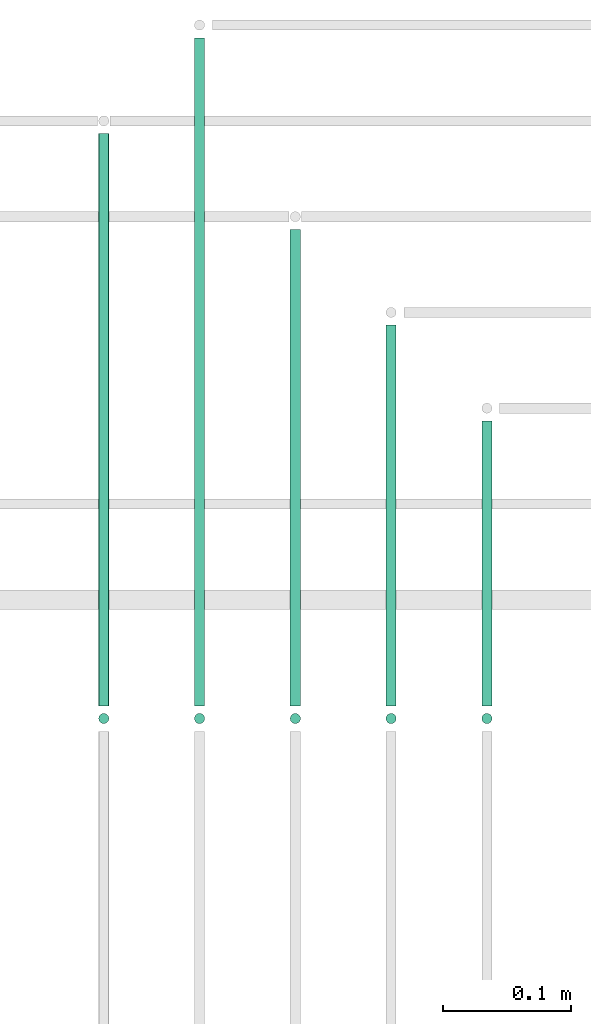
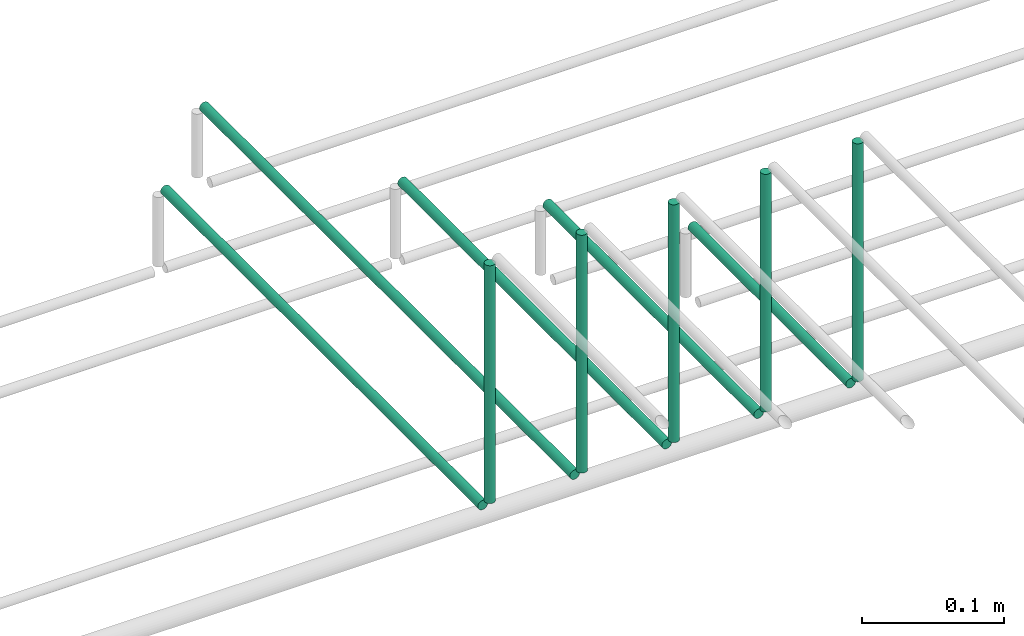
# One storey, part 44 of 89: 10 flow segments.
"""IFC2X3 building model written with IfcOpenShell, lengths in millimetres."""

from ifc_helpers import new_model, entity, si_unit, converted_unit, derived_unit, direction, frame, origin, origin_2d_with_axis, place, context, subcontext, project, spatial, circle, extrude, type_object, element, save


model = new_model("IFC2X3")

# Units and contexts
model_context = context("Model", 3, precision=0.01, world=origin(), true_north=direction((6.12303176911189e-17, 1.0)))
body_context = subcontext(model_context, "Body", "Model", "MODEL_VIEW")
ifc_project = project(units=[si_unit("LENGTHUNIT", "METRE", prefix="MILLI"), si_unit("AREAUNIT", "SQUARE_METRE"), si_unit("VOLUMEUNIT", "CUBIC_METRE"), converted_unit("PLANEANGLEUNIT", "DEGREE", entity("IfcRatioMeasure", 0.0174532925199433), si_unit("PLANEANGLEUNIT", "RADIAN"), dimensions=[0, 0, 0, 0, 0, 0, 0]), si_unit("MASSUNIT", "GRAM", prefix="KILO"), derived_unit("MASSDENSITYUNIT", [(si_unit("MASSUNIT", "GRAM", prefix="KILO"), 1), (si_unit("LENGTHUNIT", "METRE"), -3)]), derived_unit("MOMENTOFINERTIAUNIT", [(si_unit("LENGTHUNIT", "METRE"), 4)]), si_unit("TIMEUNIT", "SECOND"), si_unit("FREQUENCYUNIT", "HERTZ"), si_unit("THERMODYNAMICTEMPERATUREUNIT", "DEGREE_CELSIUS"), derived_unit("THERMALTRANSMITTANCEUNIT", [(si_unit("MASSUNIT", "GRAM", prefix="KILO"), 1), (si_unit("THERMODYNAMICTEMPERATUREUNIT", "KELVIN"), -1), (si_unit("TIMEUNIT", "SECOND"), -3)]), derived_unit("VOLUMETRICFLOWRATEUNIT", [(si_unit("LENGTHUNIT", "METRE"), 3), (si_unit("TIMEUNIT", "SECOND"), -1)]), derived_unit("MASSFLOWRATEUNIT", [(si_unit("MASSUNIT", "GRAM", prefix="KILO"), 1), (si_unit("TIMEUNIT", "SECOND"), -1)]), derived_unit("ROTATIONALFREQUENCYUNIT", [(si_unit("TIMEUNIT", "SECOND"), -1)]), si_unit("ELECTRICCURRENTUNIT", "AMPERE"), si_unit("ELECTRICVOLTAGEUNIT", "VOLT"), si_unit("POWERUNIT", "WATT"), si_unit("FORCEUNIT", "NEWTON", prefix="KILO"), si_unit("ILLUMINANCEUNIT", "LUX"), si_unit("LUMINOUSFLUXUNIT", "LUMEN"), si_unit("LUMINOUSINTENSITYUNIT", "CANDELA"), derived_unit("USERDEFINED", [(si_unit("MASSUNIT", "GRAM", prefix="KILO"), -1), (si_unit("LENGTHUNIT", "METRE"), -2), (si_unit("TIMEUNIT", "SECOND"), 3), (si_unit("LUMINOUSFLUXUNIT", "LUMEN"), 1)]), derived_unit("LINEARVELOCITYUNIT", [(si_unit("LENGTHUNIT", "METRE"), 1), (si_unit("TIMEUNIT", "SECOND"), -1)]), si_unit("PRESSUREUNIT", "PASCAL"), derived_unit("USERDEFINED", [(si_unit("LENGTHUNIT", "METRE"), -2), (si_unit("MASSUNIT", "GRAM", prefix="KILO"), 1), (si_unit("TIMEUNIT", "SECOND"), -2)]), derived_unit("LINEARFORCEUNIT", [(si_unit("MASSUNIT", "GRAM", prefix="KILO"), 1), (si_unit("LENGTHUNIT", "METRE"), 1), (si_unit("TIMEUNIT", "SECOND"), -2), (si_unit("LENGTHUNIT", "METRE"), -1)]), derived_unit("PLANARFORCEUNIT", [(si_unit("MASSUNIT", "GRAM", prefix="KILO"), 1), (si_unit("LENGTHUNIT", "METRE"), 1), (si_unit("TIMEUNIT", "SECOND"), -2), (si_unit("LENGTHUNIT", "METRE"), -2)])], contexts=[model_context])

# Site, building, storey
site_placement = place(None, frame((0.0, -0.00077364408347762, 0.0)))
site = spatial("IfcSite", under=ifc_project, at=site_placement, CompositionType="ELEMENT")
building_placement = place(site_placement, origin())
building = spatial("IfcBuilding", under=site, at=building_placement, CompositionType="ELEMENT")
storey_placement = place(building_placement, frame((0.0, 0.0, 24000.0)))
storey = spatial("IfcBuildingStorey", under=building, at=storey_placement, CompositionType="ELEMENT", Elevation=24000.0)

# Flow segments
pipe_segment_type = type_object("IfcPipeSegmentType", PredefinedType="NOTDEFINED")
flow_segment_1_placement = place(storey_placement, frame((45839.1209292422, 18567.0, 2844.4047277641)))
element("IfcFlowSegment", 1, at=flow_segment_1_placement, inside=storey, type_object=pipe_segment_type, context=body_context, shape_type="SweptSolid", body=[
    extrude(circle(Radius=4.0, at=origin_2d_with_axis()), frame((5.59527223591499, 0.0, 5.59527223591499), z_axis=(0.0, 1.0, 0.0), x_axis=(-1.0, 0.0, 0.0)), (0.0, 0.0, 1.0), 448.000007308937),
])
flow_segment_2_placement = place(storey_placement, frame((45839.1209292422, 18551.4047204553, 2860.0)))
element("IfcFlowSegment", 2, at=flow_segment_2_placement, inside=storey, type_object=pipe_segment_type, context=body_context, shape_type="SweptSolid", body=[
    extrude(circle(Radius=4.0, at=origin_2d_with_axis()), frame((5.59527223591499, 5.59527223591499, 0.0)), (0.0, 0.0, 1.0), 205.00000000001),
])
flow_segment_3_placement = place(storey_placement, frame((45914.1209292421, 18567.0, 2844.4047277641)))
element("IfcFlowSegment", 3, at=flow_segment_3_placement, inside=storey, type_object=pipe_segment_type, context=body_context, shape_type="SweptSolid", body=[
    extrude(circle(Radius=4.0, at=origin_2d_with_axis()), frame((5.59527223591499, 0.0, 5.59527223591499), z_axis=(0.0, 1.0, 0.0), x_axis=(-1.0, 0.0, 0.0)), (0.0, 0.0, 1.0), 523.000007308933),
])
flow_segment_4_placement = place(storey_placement, frame((45914.1209292421, 18551.4047204553, 2860.0)))
element("IfcFlowSegment", 4, at=flow_segment_4_placement, inside=storey, type_object=pipe_segment_type, context=body_context, shape_type="SweptSolid", body=[
    extrude(circle(Radius=4.0, at=origin_2d_with_axis()), frame((5.59527223591499, 5.59527223591499, 0.0)), (0.0, 0.0, 1.0), 205.000000000027),
])
flow_segment_5_placement = place(storey_placement, frame((45989.1209292421, 18567.0, 2844.4047277641)))
element("IfcFlowSegment", 5, at=flow_segment_5_placement, inside=storey, type_object=pipe_segment_type, context=body_context, shape_type="SweptSolid", body=[
    extrude(circle(Radius=4.0, at=origin_2d_with_axis()), frame((5.59527223591499, 0.0, 5.59527223591499), z_axis=(0.0, 1.0, 0.0), x_axis=(-1.0, 0.0, 0.0)), (0.0, 0.0, 1.0), 373.000007308917),
])
flow_segment_6_placement = place(storey_placement, frame((45989.1209292421, 18551.4047204553, 2860.0)))
element("IfcFlowSegment", 6, at=flow_segment_6_placement, inside=storey, type_object=pipe_segment_type, context=body_context, shape_type="SweptSolid", body=[
    extrude(circle(Radius=4.0, at=origin_2d_with_axis()), frame((5.59527223591499, 5.59527223591499, 0.0)), (0.0, 0.0, 1.0), 205.00000000001),
])
flow_segment_7_placement = place(storey_placement, frame((46064.1209292421, 18567.0, 2844.40472776411)))
element("IfcFlowSegment", 7, at=flow_segment_7_placement, inside=storey, type_object=pipe_segment_type, context=body_context, shape_type="SweptSolid", body=[
    extrude(circle(Radius=4.0, at=origin_2d_with_axis()), frame((5.59527223591499, 0.0, 5.59527223591499), z_axis=(0.0, 1.0, 0.0), x_axis=(-1.0, 0.0, 0.0)), (0.0, 0.0, 1.0), 298.000007308924),
])
flow_segment_8_placement = place(storey_placement, frame((46064.1209292421, 18551.4047204553, 2860.0)))
element("IfcFlowSegment", 8, at=flow_segment_8_placement, inside=storey, type_object=pipe_segment_type, context=body_context, shape_type="SweptSolid", body=[
    extrude(circle(Radius=4.0, at=origin_2d_with_axis()), frame((5.59527223591499, 5.59527223591499, 0.0)), (0.0, 0.0, 1.0), 205.00000000001),
])
flow_segment_9_placement = place(storey_placement, frame((46139.1209292421, 18567.0, 2844.40472776411)))
element("IfcFlowSegment", 9, at=flow_segment_9_placement, inside=storey, type_object=pipe_segment_type, context=body_context, shape_type="SweptSolid", body=[
    extrude(circle(Radius=4.0, at=origin_2d_with_axis()), frame((5.59527223591499, 0.0, 5.59527223591499), z_axis=(0.0, 1.0, 0.0), x_axis=(-1.0, 0.0, 0.0)), (0.0, 0.0, 1.0), 223.000007308923),
])
flow_segment_10_placement = place(storey_placement, frame((46139.1209292421, 18551.4047204553, 2860.0)))
element("IfcFlowSegment", 10, at=flow_segment_10_placement, inside=storey, type_object=pipe_segment_type, context=body_context, shape_type="SweptSolid", body=[
    extrude(circle(Radius=4.0, at=origin_2d_with_axis()), frame((5.59527223591499, 5.59527223591499, 0.0)), (0.0, 0.0, 1.0), 205.00000000001),
])

save(model, "model.ifc")
